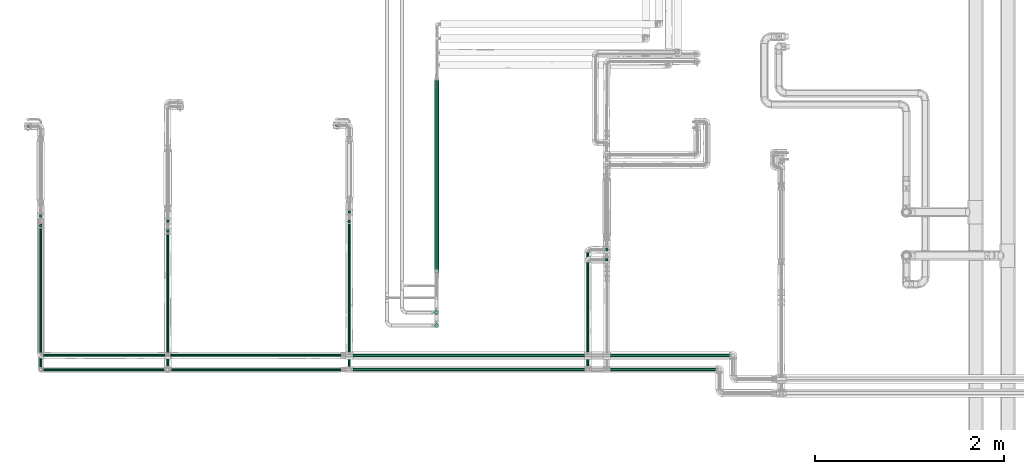
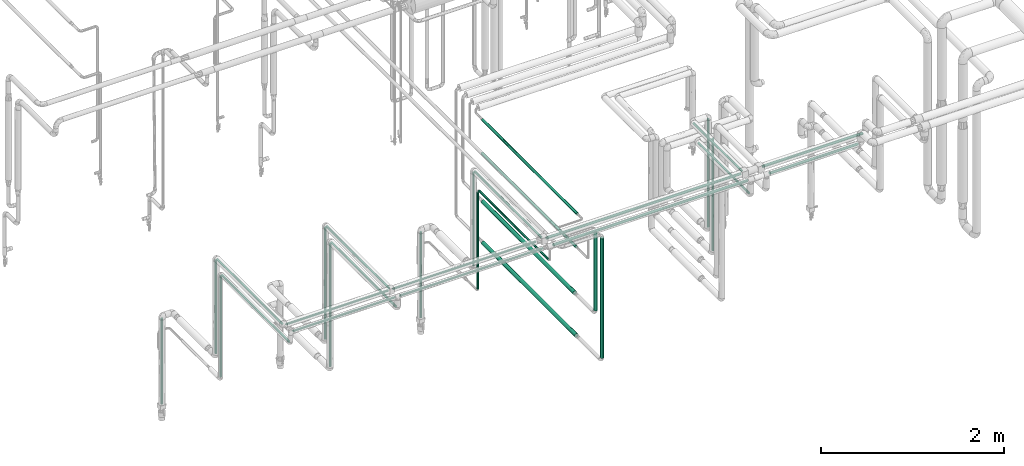
# One storey, part 519 of 827: 32 flow segments.
"""IFC2X3 building model written with IfcOpenShell, lengths in millimetres."""

from ifc_helpers import new_model, entity, si_unit, converted_unit, derived_unit, direction, frame, origin, origin_2d_with_axis, place, context, subcontext, project, spatial, circle, extrude, type_object, element, save


model = new_model("IFC2X3")

# Units and contexts
model_context = context("Model", 3, precision=0.01, world=origin(), true_north=direction((6.12303176911189e-17, 1.0)))
body_context = subcontext(model_context, "Body", "Model", "MODEL_VIEW")
ifc_project = project(units=[si_unit("LENGTHUNIT", "METRE", prefix="MILLI"), si_unit("AREAUNIT", "SQUARE_METRE"), si_unit("VOLUMEUNIT", "CUBIC_METRE"), converted_unit("PLANEANGLEUNIT", "DEGREE", entity("IfcRatioMeasure", 0.0174532925199433), si_unit("PLANEANGLEUNIT", "RADIAN"), dimensions=[0, 0, 0, 0, 0, 0, 0]), si_unit("MASSUNIT", "GRAM", prefix="KILO"), derived_unit("MASSDENSITYUNIT", [(si_unit("MASSUNIT", "GRAM", prefix="KILO"), 1), (si_unit("LENGTHUNIT", "METRE"), -3)]), derived_unit("MOMENTOFINERTIAUNIT", [(si_unit("LENGTHUNIT", "METRE"), 4)]), si_unit("TIMEUNIT", "SECOND"), si_unit("FREQUENCYUNIT", "HERTZ"), si_unit("THERMODYNAMICTEMPERATUREUNIT", "DEGREE_CELSIUS"), derived_unit("THERMALTRANSMITTANCEUNIT", [(si_unit("MASSUNIT", "GRAM", prefix="KILO"), 1), (si_unit("THERMODYNAMICTEMPERATUREUNIT", "KELVIN"), -1), (si_unit("TIMEUNIT", "SECOND"), -3)]), derived_unit("VOLUMETRICFLOWRATEUNIT", [(si_unit("LENGTHUNIT", "METRE"), 3), (si_unit("TIMEUNIT", "SECOND"), -1)]), derived_unit("MASSFLOWRATEUNIT", [(si_unit("MASSUNIT", "GRAM", prefix="KILO"), 1), (si_unit("TIMEUNIT", "SECOND"), -1)]), derived_unit("ROTATIONALFREQUENCYUNIT", [(si_unit("TIMEUNIT", "SECOND"), -1)]), si_unit("ELECTRICCURRENTUNIT", "AMPERE"), si_unit("ELECTRICVOLTAGEUNIT", "VOLT"), si_unit("POWERUNIT", "WATT"), si_unit("FORCEUNIT", "NEWTON", prefix="KILO"), si_unit("ILLUMINANCEUNIT", "LUX"), si_unit("LUMINOUSFLUXUNIT", "LUMEN"), si_unit("LUMINOUSINTENSITYUNIT", "CANDELA"), derived_unit("USERDEFINED", [(si_unit("MASSUNIT", "GRAM", prefix="KILO"), -1), (si_unit("LENGTHUNIT", "METRE"), -2), (si_unit("TIMEUNIT", "SECOND"), 3), (si_unit("LUMINOUSFLUXUNIT", "LUMEN"), 1)]), derived_unit("LINEARVELOCITYUNIT", [(si_unit("LENGTHUNIT", "METRE"), 1), (si_unit("TIMEUNIT", "SECOND"), -1)]), si_unit("PRESSUREUNIT", "PASCAL"), derived_unit("USERDEFINED", [(si_unit("LENGTHUNIT", "METRE"), -2), (si_unit("MASSUNIT", "GRAM", prefix="KILO"), 1), (si_unit("TIMEUNIT", "SECOND"), -2)]), derived_unit("LINEARFORCEUNIT", [(si_unit("MASSUNIT", "GRAM", prefix="KILO"), 1), (si_unit("LENGTHUNIT", "METRE"), 1), (si_unit("TIMEUNIT", "SECOND"), -2), (si_unit("LENGTHUNIT", "METRE"), -1)]), derived_unit("PLANARFORCEUNIT", [(si_unit("MASSUNIT", "GRAM", prefix="KILO"), 1), (si_unit("LENGTHUNIT", "METRE"), 1), (si_unit("TIMEUNIT", "SECOND"), -2), (si_unit("LENGTHUNIT", "METRE"), -2)])], contexts=[model_context])

# Site, building, storey
site_placement = place(None, origin())
site = spatial("IfcSite", under=ifc_project, at=site_placement, CompositionType="ELEMENT")
building_placement = place(site_placement, origin())
building = spatial("IfcBuilding", under=site, at=building_placement, CompositionType="ELEMENT")
storey_placement = place(building_placement, frame((0.0, 0.0, 28200.0)))
storey = spatial("IfcBuildingStorey", under=building, at=storey_placement, Name="08", CompositionType="ELEMENT", Elevation=28200.0)

# Flow segments
pipe_segment_type = type_object("IfcPipeSegmentType", PredefinedType="NOTDEFINED")
flow_segment_1_placement = place(storey_placement, frame((16103.81, 10035.05, 760.06)))
element("IfcFlowSegment", 1, at=flow_segment_1_placement, inside=storey, type_object=pipe_segment_type, context=body_context, shape_type="SweptSolid", body=[
    extrude(circle(Radius=21.15, at=origin_2d_with_axis()), frame((22.75, 22.75, 0.0)), (0.0, 0.0, 1.0), 1594.00000000001),
])
flow_segment_2_placement = place(storey_placement, frame((16103.81, 10175.23, 1306.33)))
element("IfcFlowSegment", 2, at=flow_segment_2_placement, inside=storey, type_object=pipe_segment_type, context=body_context, shape_type="SweptSolid", body=[
    extrude(circle(Radius=21.15, at=origin_2d_with_axis()), frame((22.75, 22.75, 0.0)), (0.0, 0.0, 1.0), 1045.66925284206),
])
flow_segment_3_placement = place(storey_placement, frame((11916.91, 11205.3, 1574.85)))
element("IfcFlowSegment", 3, at=flow_segment_3_placement, inside=storey, type_object=pipe_segment_type, context=body_context, shape_type="SweptSolid", body=[
    extrude(circle(Radius=13.4, at=origin_2d_with_axis()), frame((15.0, 15.0, 0.0)), (0.0, 0.0, 1.0), 1246.05413609899),
])
flow_segment_4_placement = place(storey_placement, frame((11916.91, 9771.9, 2835.01)))
element("IfcFlowSegment", 4, at=flow_segment_4_placement, inside=storey, type_object=pipe_segment_type, context=body_context, shape_type="SweptSolid", body=[
    extrude(circle(Radius=13.4, at=origin_2d_with_axis()), frame((15.0, 0.0, 15.0), z_axis=(0.0, 1.0, 0.0), x_axis=(1.0, 0.0, 0.0)), (0.0, 0.0, 1.0), 1419.29999999993),
])
flow_segment_5_placement = place(storey_placement, frame((11916.91, 9621.9, 2685.0)))
element("IfcFlowSegment", 5, at=flow_segment_5_placement, inside=storey, type_object=pipe_segment_type, context=body_context, shape_type="SweptSolid", body=[
    extrude(circle(Radius=13.4, at=origin_2d_with_axis()), frame((15.0, 0.0, 15.0), z_axis=(0.0, 1.0, 0.0), x_axis=(1.0, 0.0, 0.0)), (0.0, 0.0, 1.0), 1466.8851148285),
])
flow_segment_6_placement = place(storey_placement, frame((11916.91, 11102.89, 1328.45)))
element("IfcFlowSegment", 6, at=flow_segment_6_placement, inside=storey, type_object=pipe_segment_type, context=body_context, shape_type="SweptSolid", body=[
    extrude(circle(Radius=13.4, at=origin_2d_with_axis()), frame((15.0, 15.0, 0.0)), (0.0, 0.0, 1.0), 1342.44557612682),
])
flow_segment_7_placement = place(storey_placement, frame((13263.8, 11149.54, 1329.1)))
element("IfcFlowSegment", 7, at=flow_segment_7_placement, inside=storey, type_object=pipe_segment_type, context=body_context, shape_type="SweptSolid", body=[
    extrude(circle(Radius=13.4, at=origin_2d_with_axis()), frame((15.0, 15.0, 0.0)), (0.0, 0.0, 1.0), 1491.82774951159),
])
flow_segment_8_placement = place(storey_placement, frame((13263.8, 9771.8, 2835.01)))
element("IfcFlowSegment", 8, at=flow_segment_8_placement, inside=storey, type_object=pipe_segment_type, context=body_context, shape_type="SweptSolid", body=[
    extrude(circle(Radius=13.4, at=origin_2d_with_axis()), frame((15.0, 0.0, 15.0), z_axis=(0.0, 1.0, 1.99428167433387e-05), x_axis=(1.0, 0.0, 0.0)), (0.0, 0.0, 1.0), 1363.44050502158),
])
flow_segment_9_placement = place(storey_placement, frame((13263.8, 11045.39, 1029.11)))
element("IfcFlowSegment", 9, at=flow_segment_9_placement, inside=storey, type_object=pipe_segment_type, context=body_context, shape_type="SweptSolid", body=[
    extrude(circle(Radius=13.4, at=origin_2d_with_axis()), frame((15.0, 15.0, 0.0)), (0.0, 0.0, 1.0), 1641.79389074725),
])
flow_segment_10_placement = place(storey_placement, frame((15185.93, 11245.3, 1574.85)))
element("IfcFlowSegment", 10, at=flow_segment_10_placement, inside=storey, type_object=pipe_segment_type, context=body_context, shape_type="SweptSolid", body=[
    extrude(circle(Radius=13.4, at=origin_2d_with_axis()), frame((15.0, 15.0, 0.0)), (0.0, 0.0, 1.0), 1246.20860226404),
])
flow_segment_11_placement = place(storey_placement, frame((15185.93, 9780.8, 2835.09)))
element("IfcFlowSegment", 11, at=flow_segment_11_placement, inside=storey, type_object=pipe_segment_type, context=body_context, shape_type="SweptSolid", body=[
    extrude(circle(Radius=13.4, at=origin_2d_with_axis()), frame((15.0, 0.0, 15.0), z_axis=(3.04157647443826e-08, 1.0, 4.57276515440939e-05), x_axis=(-1.0, 3.04157647761826e-08, 0.0)), (0.0, 0.0, 1.0), 1450.40578677607),
])
flow_segment_12_placement = place(storey_placement, frame((15184.68, 11147.89, 1328.45)))
element("IfcFlowSegment", 12, at=flow_segment_12_placement, inside=storey, type_object=pipe_segment_type, context=body_context, shape_type="SweptSolid", body=[
    extrude(circle(Radius=13.4, at=origin_2d_with_axis()), frame((15.0, 15.0, 0.0)), (0.0, 0.0, 1.0), 1292.44557612681),
])
flow_segment_13_placement = place(storey_placement, frame((17913.53, 10848.44, 1377.35)))
element("IfcFlowSegment", 13, at=flow_segment_13_placement, inside=storey, type_object=pipe_segment_type, context=body_context, shape_type="SweptSolid", body=[
    extrude(circle(Radius=13.4, at=origin_2d_with_axis()), frame((15.0, 15.0, 0.0)), (0.0, 0.0, 1.0), 1443.65777278406),
])
flow_segment_14_placement = place(storey_placement, frame((17713.53, 9780.8, 2835.05)))
element("IfcFlowSegment", 14, at=flow_segment_14_placement, inside=storey, type_object=pipe_segment_type, context=body_context, shape_type="SweptSolid", body=[
    extrude(circle(Radius=13.4, at=origin_2d_with_axis()), frame((15.0, 0.0, 15.0), z_axis=(0.0, 0.999999996801629, 7.99796377782255e-05), x_axis=(1.0, 0.0, 0.0)), (0.0, 0.0, 1.0), 1050.42462903589),
])
flow_segment_15_placement = place(storey_placement, frame((17713.53, 9621.9, 2636.73)))
element("IfcFlowSegment", 15, at=flow_segment_15_placement, inside=storey, type_object=pipe_segment_type, context=body_context, shape_type="SweptSolid", body=[
    extrude(circle(Radius=13.4, at=origin_2d_with_axis()), frame((15.0, 0.0, 15.0), z_axis=(0.0, 1.0, 0.0), x_axis=(-1.0, 0.0, 0.0)), (0.0, 0.0, 1.0), 1105.23013999997),
])
flow_segment_16_placement = place(storey_placement, frame((17912.28, 10741.23, 1131.62)))
element("IfcFlowSegment", 16, at=flow_segment_16_placement, inside=storey, type_object=pipe_segment_type, context=body_context, shape_type="SweptSolid", body=[
    extrude(circle(Radius=13.4, at=origin_2d_with_axis()), frame((15.0, 15.0, 0.0)), (0.0, 0.0, 1.0), 1491.01242102765),
])
flow_segment_17_placement = place(storey_placement, frame((11961.0, 9727.8, 2835.01)))
element("IfcFlowSegment", 17, at=flow_segment_17_placement, inside=storey, type_object=pipe_segment_type, context=body_context, shape_type="SweptSolid", body=[
    extrude(circle(Radius=13.4, at=origin_2d_with_axis()), frame((0.0, 15.0, 15.0), z_axis=(1.0, 0.0, 0.0), x_axis=(0.0, -1.0, 0.0)), (0.0, 0.0, 1.0), 1288.79281819058),
])
flow_segment_18_placement = place(storey_placement, frame((11961.01, 9577.8, 2835.0)))
element("IfcFlowSegment", 18, at=flow_segment_18_placement, inside=storey, type_object=pipe_segment_type, context=body_context, shape_type="SweptSolid", body=[
    extrude(circle(Radius=13.4, at=origin_2d_with_axis()), frame((0.0, 15.0, 15.0), z_axis=(1.0, 0.0, 0.0), x_axis=(0.0, -1.0, 0.0)), (0.0, 0.0, 1.0), 1287.54289948289),
])
flow_segment_19_placement = place(storey_placement, frame((15238.92, 9724.45, 2831.7)))
element("IfcFlowSegment", 19, at=flow_segment_19_placement, inside=storey, type_object=pipe_segment_type, context=body_context, shape_type="SweptSolid", body=[
    extrude(circle(Radius=16.75, at=origin_2d_with_axis()), frame((2451.6, 18.35, 18.35), z_axis=(-1.0, 0.0, 1.9264196019509e-05), x_axis=(0.0, -1.0, 0.0)), (0.0, 0.0, 1.0), 2451.60034095253),
])
flow_segment_20_placement = place(storey_placement, frame((13306.55, 9577.8, 2835.0)))
element("IfcFlowSegment", 20, at=flow_segment_20_placement, inside=storey, type_object=pipe_segment_type, context=body_context, shape_type="SweptSolid", body=[
    extrude(circle(Radius=13.4, at=origin_2d_with_axis()), frame((0.0, 15.0, 15.0), z_axis=(1.0, 0.0, 0.0), x_axis=(0.0, 1.0, 0.0)), (0.0, 0.0, 1.0), 1805.37544866203),
])
flow_segment_21_placement = place(storey_placement, frame((11783.21, 12155.04, 376.5)))
element("IfcFlowSegment", 21, at=flow_segment_21_placement, inside=storey, type_object=pipe_segment_type, context=body_context, shape_type="SweptSolid", body=[
    extrude(circle(Radius=13.4, at=origin_2d_with_axis()), frame((15.0, 15.0, 0.0)), (0.0, 0.0, 1.0), 1140.14572643597),
])
flow_segment_22_placement = place(storey_placement, frame((15051.98, 12164.42, 376.5)))
element("IfcFlowSegment", 22, at=flow_segment_22_placement, inside=storey, type_object=pipe_segment_type, context=body_context, shape_type="SweptSolid", body=[
    extrude(circle(Radius=13.4, at=origin_2d_with_axis()), frame((15.0, 15.0, 0.0), z_axis=(0.0, 7.23004426404658e-06, 1.0), x_axis=(-1.0, 0.0, 0.0)), (0.0, 0.0, 1.0), 1140.14638458189),
])
flow_segment_23_placement = place(storey_placement, frame((16109.71, 10597.41, 2323.48)))
element("IfcFlowSegment", 23, at=flow_segment_23_placement, inside=storey, type_object=pipe_segment_type, context=body_context, shape_type="SweptSolid", body=[
    extrude(circle(Radius=16.75, at=origin_2d_with_axis()), frame((18.35, 0.0, 18.35), z_axis=(0.0, 1.0, 0.0), x_axis=(-1.0, 0.0, 0.0)), (0.0, 0.0, 1.0), 2069.00000000001),
])
flow_segment_24_placement = place(storey_placement, frame((16100.96, 10651.97, 1232.74)))
element("IfcFlowSegment", 24, at=flow_segment_24_placement, inside=storey, type_object=pipe_segment_type, context=body_context, shape_type="SweptSolid", body=[
    extrude(circle(Radius=24.0, at=origin_2d_with_axis()), frame((25.6, 0.0, 25.6), z_axis=(0.0, 1.0, 0.0), x_axis=(-1.0, 0.0, 0.0)), (0.0, 0.0, 1.0), 2005.62560995536),
])
flow_segment_25_placement = place(storey_placement, frame((16100.96, 10616.8, 686.46)))
element("IfcFlowSegment", 25, at=flow_segment_25_placement, inside=storey, type_object=pipe_segment_type, context=body_context, shape_type="SweptSolid", body=[
    extrude(circle(Radius=24.0, at=origin_2d_with_axis()), frame((25.6, 0.0, 25.6), z_axis=(0.0, 1.0, 0.0), x_axis=(-1.0, 0.0, 0.0)), (0.0, 0.0, 1.0), 2037.11513347605),
])
flow_segment_26_placement = place(storey_placement, frame((16107.99, 10618.67, 1874.26)))
element("IfcFlowSegment", 26, at=flow_segment_26_placement, inside=storey, type_object=pipe_segment_type, context=body_context, shape_type="SweptSolid", body=[
    extrude(circle(Radius=16.75, at=origin_2d_with_axis()), frame((18.35, 0.01, 18.35), z_axis=(0.000747998840608372, 0.999999720248828, 0.0), x_axis=(0.999999720248828, -0.000747998840608372, 0.0)), (0.0, 0.0, 1.0), 2056.89458974757),
])
flow_segment_27_placement = place(storey_placement, frame((17966.52, 9724.45, 2831.67)))
element("IfcFlowSegment", 27, at=flow_segment_27_placement, inside=storey, type_object=pipe_segment_type, context=body_context, shape_type="SweptSolid", body=[
    extrude(circle(Radius=16.75, at=origin_2d_with_axis()), frame((1262.96, 18.35, 18.35), z_axis=(-1.0, 0.0, 1.92641960413658e-05), x_axis=(0.0, -1.0, 0.0)), (0.0, 0.0, 1.0), 1262.95794273614),
])
flow_segment_28_placement = place(storey_placement, frame((17966.53, 9574.45, 2831.65)))
element("IfcFlowSegment", 28, at=flow_segment_28_placement, inside=storey, type_object=pipe_segment_type, context=body_context, shape_type="SweptSolid", body=[
    extrude(circle(Radius=16.75, at=origin_2d_with_axis()), frame((0.0, 18.35, 18.35), z_axis=(1.0, 0.0, 0.0), x_axis=(0.0, 1.0, 0.0)), (0.0, 0.0, 1.0), 1117.61105241123),
])
flow_segment_29_placement = place(storey_placement, frame((15184.49, 9621.89, 2635.0)))
element("IfcFlowSegment", 29, at=flow_segment_29_placement, inside=storey, type_object=pipe_segment_type, context=body_context, shape_type="SweptSolid", body=[
    extrude(circle(Radius=13.4, at=origin_2d_with_axis()), frame((15.0, 1511.9, 15.0), z_axis=(0.000938332447983894, -0.999999559766012, 0.0), x_axis=(-0.999999559766012, -0.000938332447983894, 0.0)), (0.0, 0.0, 1.0), 1511.88559680005),
])
flow_segment_30_placement = place(storey_placement, frame((15238.92, 9574.45, 2831.65)))
element("IfcFlowSegment", 30, at=flow_segment_30_placement, inside=storey, type_object=pipe_segment_type, context=body_context, shape_type="SweptSolid", body=[
    extrude(circle(Radius=16.75, at=origin_2d_with_axis()), frame((0.0, 18.35, 18.35), z_axis=(1.0, 0.0, 0.0), x_axis=(0.0, 1.0, 0.0)), (0.0, 0.0, 1.0), 2451.60029353856),
])
flow_segment_31_placement = place(storey_placement, frame((13307.8, 9727.8, 2835.0)))
element("IfcFlowSegment", 31, at=flow_segment_31_placement, inside=storey, type_object=pipe_segment_type, context=body_context, shape_type="SweptSolid", body=[
    extrude(circle(Radius=13.4, at=origin_2d_with_axis()), frame((0.0, 15.0, 15.0), z_axis=(1.0, 0.0, 5.0425624807851e-05), x_axis=(0.0, 1.0, 0.0)), (0.0, 0.0, 1.0), 1804.12844893694),
])
flow_segment_32_placement = place(storey_placement, frame((13263.8, 9621.9, 2685.0)))
element("IfcFlowSegment", 32, at=flow_segment_32_placement, inside=storey, type_object=pipe_segment_type, context=body_context, shape_type="SweptSolid", body=[
    extrude(circle(Radius=13.4, at=origin_2d_with_axis()), frame((15.0, 0.0, 15.0), z_axis=(0.0, 1.0, 0.0), x_axis=(-1.0, 0.0, 0.0)), (0.0, 0.0, 1.0), 1409.38511482851),
])

save(model, "model.ifc")
